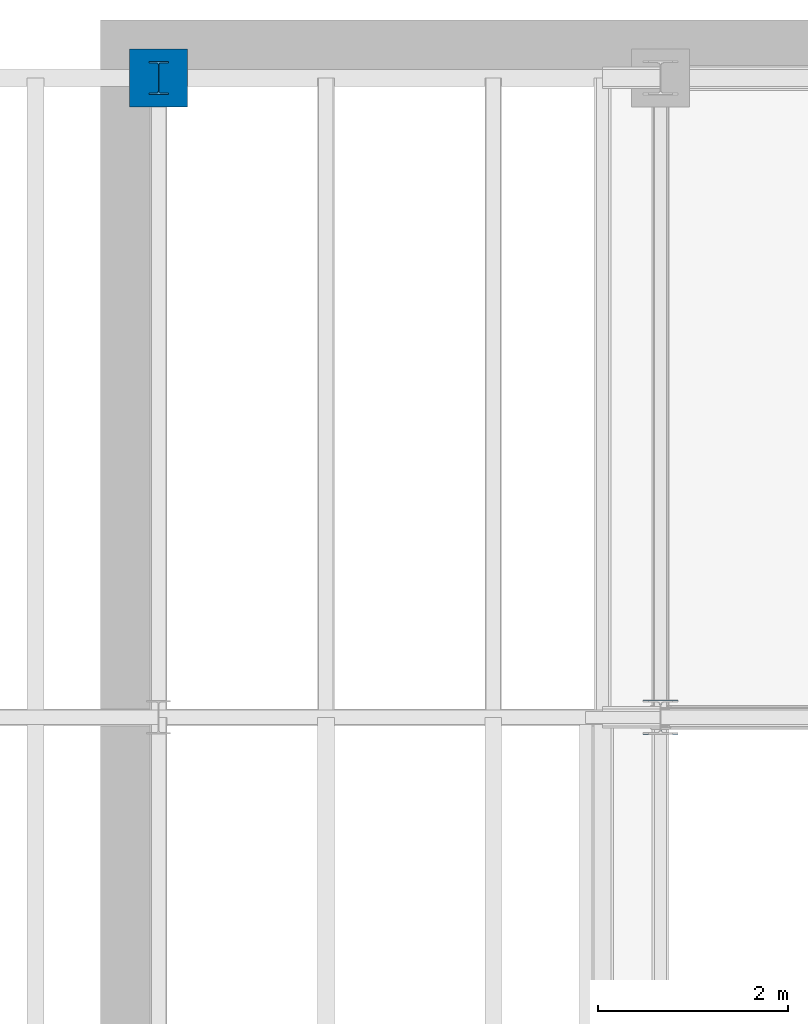
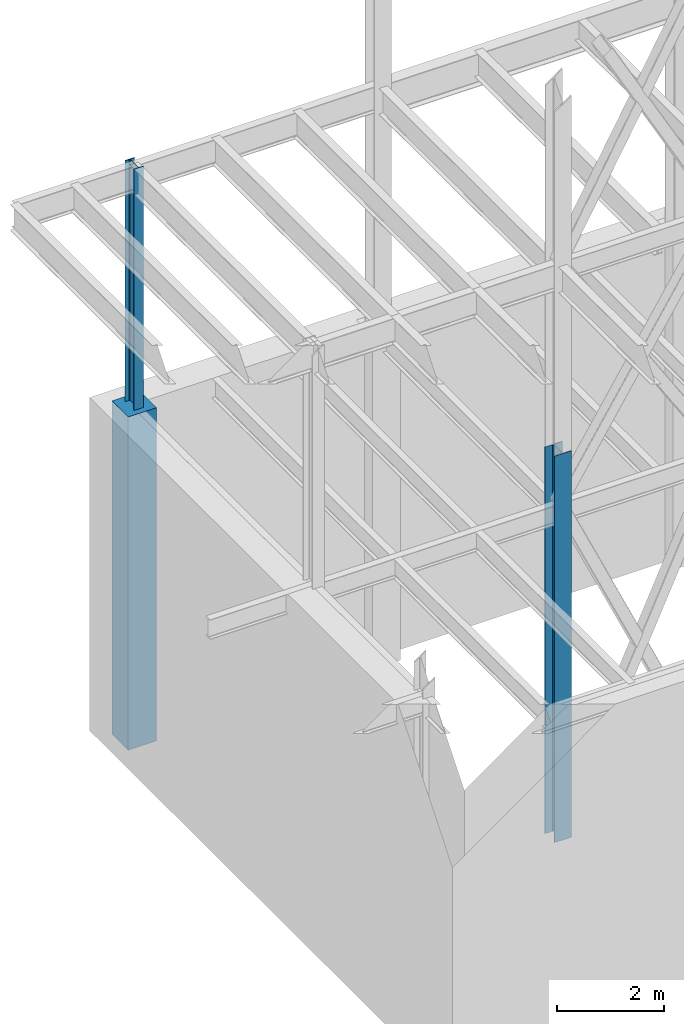
# One storey, part 52 of 150: 3 columns.
"""IFC2X3 building model written with IfcOpenShell, lengths in millimetres."""

from ifc_helpers import new_model, si_unit, frame, origin_with_axes, origin_2d_with_axis, place, context, subcontext, project, spatial, rectangle, i_section, extrude, material, type_object, element, save


model = new_model("IFC2X3")

# Units and contexts
model_context = context("Model", 3, precision=1e-05, world=origin_with_axes())
body_context = subcontext(model_context, "Body", "Model", "MODEL_VIEW")
ifc_project = project(units=[si_unit("LENGTHUNIT", "METRE", prefix="MILLI"), si_unit("AREAUNIT", "SQUARE_METRE"), si_unit("VOLUMEUNIT", "CUBIC_METRE"), si_unit("MASSUNIT", "GRAM", prefix="KILO"), si_unit("TIMEUNIT", "SECOND"), si_unit("PLANEANGLEUNIT", "RADIAN"), si_unit("SOLIDANGLEUNIT", "STERADIAN"), si_unit("THERMODYNAMICTEMPERATUREUNIT", "DEGREE_CELSIUS"), si_unit("LUMINOUSINTENSITYUNIT", "LUMEN")], contexts=[model_context])

# Site, building, storey
site_placement = place(None, origin_with_axes())
site = spatial("IfcSite", under=ifc_project, at=site_placement, CompositionType="ELEMENT")
building_placement = place(site_placement, origin_with_axes())
building = spatial("IfcBuilding", under=site, at=building_placement, Name="Undefined", CompositionType="ELEMENT")
storey_placement = place(building_placement, origin_with_axes())
storey = spatial("IfcBuildingStorey", under=building, at=storey_placement, Name="Undefined", CompositionType="ELEMENT", Elevation=0.0)

# Columns
ifc_material_1 = material(Name="STEEL/A992")
column_type_1 = type_object("IfcColumnType", Name="W14X43", PredefinedType="NOTDEFINED")
column_1_placement = place(storey_placement, frame((0.0, 38862.0, 22707.6), z_axis=(0.0, 0.0, 1.0), x_axis=(1.0, 0.0, 0.0)))
element("IfcColumn", 1, at=column_1_placement, inside=storey, type_object=column_type_1, material=ifc_material_1, Name="COLUMN", ObjectType="W14X43", context=body_context, shape_type="SweptSolid", body=[
    extrude(i_section(OverallWidth=203.2, OverallDepth=346.075, WebThickness=7.9375, FlangeThickness=13.462, FilletRadius=21.4629, at=origin_2d_with_axis()), frame((0.0, 0.0, 6578.60000000001), z_axis=(0.0, 0.0, -1.0), x_axis=(-1.0, 0.0, 0.0)), (0.0, 0.0, 1.0), 6578.60000000001),
])
column_type_2 = type_object("IfcColumnType", Name="W14X109", PredefinedType="NOTDEFINED")
column_2_placement = place(storey_placement, frame((5283.2, 32131.0, 16154.4), z_axis=(0.0, 0.0, 1.0), x_axis=(1.0, 0.0, 0.0)))
element("IfcColumn", 2, at=column_2_placement, inside=storey, type_object=column_type_2, material=ifc_material_1, Name="COLUMN", ObjectType="W14X109", context=body_context, shape_type="SweptSolid", body=[
    extrude(i_section(OverallWidth=370.84, OverallDepth=365.125, WebThickness=12.6999, FlangeThickness=21.844, FilletRadius=33.7184, at=origin_2d_with_axis()), frame((0.0, 0.0, 8839.2), z_axis=(0.0, 0.0, -1.0), x_axis=(-1.0, 0.0, 0.0)), (0.0, 0.0, 1.0), 8839.2),
])
ifc_material_2 = material(Name="CONCRETE/5000")
column_type_3 = type_object("IfcColumnType", PredefinedType="NOTDEFINED")
column_3_placement = place(storey_placement, frame((0.0, 38862.0, 16154.4), z_axis=(0.0, 0.0, 1.0), x_axis=(1.0, 0.0, 0.0)))
element("IfcColumn", 3, at=column_3_placement, inside=storey, type_object=column_type_3, material=ifc_material_2, Name="COLUMN", context=body_context, shape_type="SweptSolid", body=[
    extrude(rectangle(XDim=609.6, YDim=609.6, at=origin_2d_with_axis()), frame((0.0, 0.0, 7620.0), z_axis=(0.0, 0.0, -1.0), x_axis=(0.0, -1.0, 0.0)), (0.0, 0.0, 1.0), 7620.0),
])

save(model, "model.ifc")
